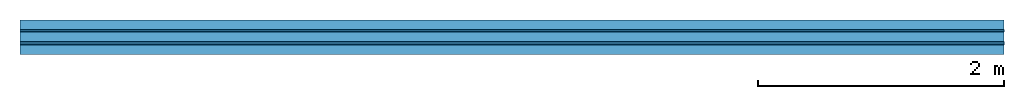
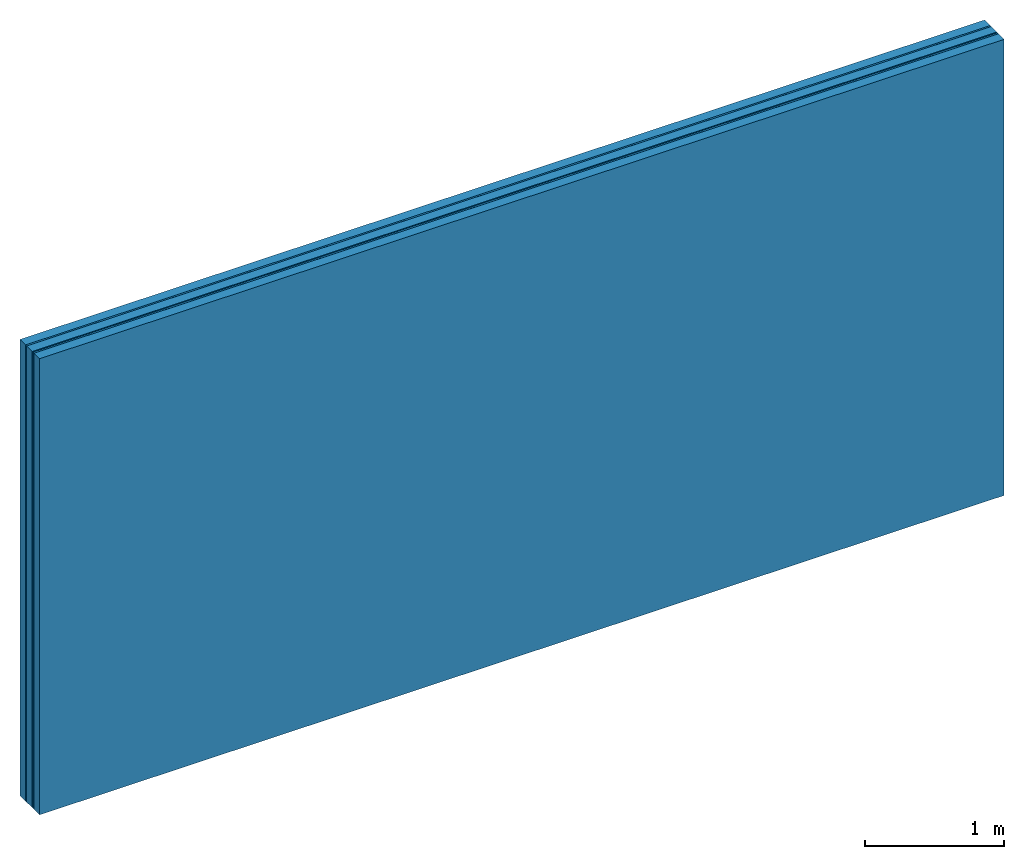
# One storey: 4 plates, 2 members, 1 element without a shape of its own.
"""IFC4 building model written with IfcOpenShell, lengths in metres."""

import ifcopenshell
import ifcopenshell.guid

model = None  # the IFC model being written
_history = None  # IfcOwnerHistory: only IFC2X3 demands one
_inside = {}  # id of a spatial element -> (the spatial element, [elements in it])
_under = {}  # id of a project, library or spatial element -> (it, [spatial elements below it])
_declared = {}  # id of a project -> (the project, [libraries it declares])
_typed = {}  # id of a type object -> (the type object, [elements of that type])
_made_of = {}  # id of a material, layer set ... -> (it, [elements and type objects made of it])


def new_model(schema):
    """Start an empty IFC model of exactly this schema.

    Asked for "IFC4X3", IfcOpenShell would pick the latest addendum, in which some entities
    have other attributes; the version numbers below select the first issue.
    IFC2X3 requires an IfcOwnerHistory on every rooted entity: one is made here for all.
    """
    global model, _history
    if schema == "IFC4X3":
        model = ifcopenshell.file(schema_version=(4, 3, 0, 0))
    else:
        model = ifcopenshell.file(schema=schema)
    _inside.clear()
    _under.clear()
    _declared.clear()
    _typed.clear()
    _made_of.clear()
    _history = None
    if model.schema == "IFC2X3":
        org = make("IfcOrganization", Name="unknown")
        user = make(
            "IfcPersonAndOrganization",
            ThePerson=make("IfcPerson", FamilyName="unknown"),
            TheOrganization=org,
        )
        app = make(
            "IfcApplication",
            ApplicationDeveloper=org,
            Version="unknown",
            ApplicationFullName="unknown",
            ApplicationIdentifier="unknown",
        )
        _history = make(
            "IfcOwnerHistory",
            OwningUser=user,
            OwningApplication=app,
            ChangeAction="ADDED",
            CreationDate=0,
        )
    return model


def make(cls, **values):
    """One entity of the class cls with the attributes given. An attribute that is None is left unset."""
    return model.create_entity(
        cls, **{name: value for name, value in values.items() if value is not None}
    )


def rooted(cls, **values):
    """An entity with a GlobalId (a new one), such as an element, a storey or a relation."""
    return make(cls, GlobalId=ifcopenshell.guid.new(), OwnerHistory=_history, **values)


def si_unit(unit_type, name, prefix=None):
    """IfcSIUnit, for example si_unit("LENGTHUNIT", "METRE", prefix="MILLI")."""
    return make("IfcSIUnit", UnitType=unit_type, Prefix=prefix, Name=name)


def derived_unit(unit_type, elements):
    """IfcDerivedUnit: a product of units, each with its exponent."""
    return make(
        "IfcDerivedUnit",
        Elements=[
            make("IfcDerivedUnitElement", Unit=unit, Exponent=power)
            for unit, power in elements
        ],
        UnitType=unit_type,
    )


def assignment(units):
    """IfcUnitAssignment: the units of a project."""
    return None if units is None else make("IfcUnitAssignment", Units=units)


def point(xyz):
    """IfcCartesianPoint."""
    return None if xyz is None else make("IfcCartesianPoint", Coordinates=xyz)


def direction(xyz):
    """IfcDirection."""
    return None if xyz is None else make("IfcDirection", DirectionRatios=xyz)


def frame(location, z_axis=None, x_axis=None):
    """IfcAxis2Placement3D, a coordinate frame: its origin and axes. An axis left out is left unset."""
    return make(
        "IfcAxis2Placement3D",
        Location=point(location),
        Axis=direction(z_axis),
        RefDirection=direction(x_axis),
    )


def frame_2d(location, x_axis=None):
    """IfcAxis2Placement2D, a coordinate frame in the plane: its origin and x axis."""
    return make(
        "IfcAxis2Placement2D", Location=point(location), RefDirection=direction(x_axis)
    )


def origin():
    """The frame at (0, 0, 0) with its axes left unset."""
    return frame((0.0, 0.0, 0.0))


def place(relative_to, where):
    """IfcLocalPlacement: puts the frame where relative to a parent placement (None: the world)."""
    return make(
        "IfcLocalPlacement", PlacementRelTo=relative_to, RelativePlacement=where
    )


def context(
    kind, dimensions, precision=None, world=None, true_north=None, identifier=None
):
    """IfcGeometricRepresentationContext, for example the 3D "Model" context."""
    return make(
        "IfcGeometricRepresentationContext",
        ContextIdentifier=identifier,
        ContextType=kind,
        CoordinateSpaceDimension=dimensions,
        Precision=precision,
        WorldCoordinateSystem=world,
        TrueNorth=true_north,
    )


def project(units=None, contexts=None):
    """IfcProject with its units and contexts."""
    return rooted(
        "IfcProject",
        Name="project",
        RepresentationContexts=contexts,
        UnitsInContext=assignment(units),
    )


def spatial(cls, under=None, at=None, **own):
    """A site, building, storey or space (cls), placed at a placement, below another one or the project."""
    s = rooted(cls, ObjectPlacement=at, **own)
    if under is not None:
        _under.setdefault(under.id(), (under, []))[1].append(s)
    return s


def profile(cls, at=None, kind="AREA", **sizes):
    """A parametric profile (cls). Its sizes go by their IFC names, for example OverallWidth=200.0."""
    return make(cls, ProfileType=kind, Position=at, **sizes)


def rectangle(**sizes):
    """IfcRectangleProfileDef."""
    return profile("IfcRectangleProfileDef", **sizes)


def extrude(swept, where, along, depth):
    """IfcExtrudedAreaSolid: the profile swept, set in the frame where, extruded along a direction by depth."""
    return make(
        "IfcExtrudedAreaSolid",
        SweptArea=swept,
        Position=where,
        ExtrudedDirection=direction(along),
        Depth=depth,
    )


def shape(context_of_items, identifier, shape_type, items):
    """IfcShapeRepresentation: the items that make up one representation, for example the "Body"."""
    return make(
        "IfcShapeRepresentation",
        ContextOfItems=context_of_items,
        RepresentationIdentifier=identifier,
        RepresentationType=shape_type,
        Items=items,
    )


def material(Name=None, Category=None):
    """IfcMaterial."""
    return make("IfcMaterial", Name=Name, Category=Category)


def layer(
    of_material, thickness, ventilated=None, Name=None, Category=None, Priority=None
):
    """IfcMaterialLayer: one layer of a wall or slab, of a material (None: an air gap)."""
    return make(
        "IfcMaterialLayer",
        Material=of_material,
        LayerThickness=thickness,
        IsVentilated=ventilated,
        Name=Name,
        Category=Category,
        Priority=Priority,
    )


def layer_set(layers, Name=None):
    """IfcMaterialLayerSet."""
    return make("IfcMaterialLayerSet", MaterialLayers=layers, LayerSetName=Name)


def made_of(thing, what):
    """Note that an element or type object is made of a material, layer set ...; save() writes the relation."""
    if what is not None:
        _made_of.setdefault(what.id(), (what, []))[1].append(thing)
    return thing


def type_object(cls, material=None, **own):
    """A type object (cls), such as IfcWallType, which elements share."""
    return made_of(rooted(cls, **own), material)


def element(
    cls,
    number,
    at=None,
    inside=None,
    cuts=None,
    type_object=None,
    material=None,
    context=None,
    identifier="Body",
    shape_type=None,
    held_by="IfcProductDefinitionShape",
    body=None,
    shapes=None,
    **own,
):
    """One element of the class cls, such as IfcWall. Its Tag is "e" and its number.

    at: its placement. inside: the storey or other place that contains it. cuts: it is an
    opening in that element (IfcRelVoidsElement). A single representation is given by context,
    identifier, shape_type and body (its items); several are given by shapes. held_by: the class
    of the entity that holds the representations. save() writes the other relations.
    """
    e = rooted(cls, Tag="e%d" % number, ObjectPlacement=at, **own)
    if body is not None:
        shapes = [shape(context, identifier, shape_type, body)]
    if shapes is not None:
        e.Representation = make(held_by, Representations=shapes)
    if inside is not None:
        _inside.setdefault(inside.id(), (inside, []))[1].append(e)
    if cuts is not None:
        rooted(
            "IfcRelVoidsElement", RelatingBuildingElement=cuts, RelatedOpeningElement=e
        )
    if type_object is not None:
        _typed.setdefault(type_object.id(), (type_object, []))[1].append(e)
    return made_of(e, material)


def aggregate(whole, parts):
    """IfcRelAggregates: a whole, such as a stair, and the parts it consists of."""
    return rooted("IfcRelAggregates", RelatingObject=whole, RelatedObjects=parts)


def save(model, path):
    """Write the relations noted so far, then the file.

    IfcRelAggregates (storeys below a building ...), IfcRelContainedInSpatialStructure (elements
    in a storey), IfcRelDefinesByType, IfcRelAssociatesMaterial and IfcRelDeclares: one each for
    every whole, place, type object, material and project.
    """
    for whole, parts in _under.values():
        aggregate(whole, parts)
    for where, things in _inside.values():
        rooted(
            "IfcRelContainedInSpatialStructure",
            RelatedElements=things,
            RelatingStructure=where,
        )
    for kind, things in _typed.values():
        rooted("IfcRelDefinesByType", RelatedObjects=things, RelatingType=kind)
    for what, things in _made_of.values():
        rooted("IfcRelAssociatesMaterial", RelatedObjects=things, RelatingMaterial=what)
    for by, libraries in _declared.values():
        rooted("IfcRelDeclares", RelatingContext=by, RelatedDefinitions=libraries)
    model.write(path)


model = new_model("IFC4")

# Units and contexts
plan_context = context("Plan", 3, precision=1e-05, world=origin(), true_north=direction((0.0, 1.0)))
model_context = context("Model", 3, precision=1e-05, world=origin(), true_north=direction((0.0, 1.0)))
ifc_project = project(units=[si_unit("LENGTHUNIT", "METRE"), derived_unit("SOUNDPRESSUREUNIT", [(si_unit("PRESSUREUNIT", "PASCAL", prefix="MICRO"), 0)]), si_unit("ENERGYUNIT", "JOULE", prefix="MEGA"), si_unit("MASSUNIT", "GRAM", prefix="KILO"), derived_unit("THERMALTRANSMITTANCEUNIT", [(si_unit("POWERUNIT", "WATT"), 1), (si_unit("AREAUNIT", "SQUARE_METRE"), -1), (si_unit("THERMODYNAMICTEMPERATUREUNIT", "KELVIN"), -1)]), derived_unit("AREADENSITYUNIT", [(si_unit("MASSUNIT", "GRAM", prefix="KILO"), 1), (si_unit("AREAUNIT", "SQUARE_METRE"), -1)]), derived_unit("USERDEFINED", [(si_unit("ENERGYUNIT", "JOULE", prefix="MEGA"), 1), (si_unit("AREAUNIT", "SQUARE_METRE"), -1)])], contexts=[plan_context, model_context])

# Site, building, storey
site = spatial("IfcSite", under=ifc_project)
building_placement = place(None, origin())
building = spatial("IfcBuilding", under=site, at=building_placement)
storey_placement = place(building_placement, origin())
storey = spatial("IfcBuildingStorey", under=building, at=storey_placement)

# Wall, members, plates
ifc_material_1 = material(Name="of the art")
ifc_layer_1 = layer(ifc_material_1, 0.0, Name="Bond")
ifc_layer_2 = layer(None, 0.08, Name="Support")
ifc_layer_3 = layer(ifc_material_1, 0.0, Name="Bond")
ifc_material_2 = material(Category="03.007")
ifc_layer_4 = layer(ifc_material_2, 0.015, Name="outside 1st layer")
ifc_material_3 = material(Category="10.008")
ifc_layer_5 = layer(ifc_material_3, 0.08, Name="Intermediate insulation")
ifc_material_4 = material(Name="Air")
ifc_layer_6 = layer(ifc_material_4, 0.01, Name="Air gap")
ifc_layer_7 = layer(ifc_material_2, 0.015, Name="outside 1st layer")
ifc_layer_8 = layer(ifc_material_1, 0.0, Name="Bond")
ifc_layer_9 = layer(None, 0.08, Name="Support")
ifc_layer_10 = layer(ifc_material_1, 0.0, Name="Bond")
ifc_layer_set = layer_set([ifc_layer_1, ifc_layer_2, ifc_layer_3, ifc_layer_4, ifc_layer_5, ifc_layer_6, ifc_layer_7, ifc_layer_8, ifc_layer_9, ifc_layer_10])
wall_type = type_object("IfcWallType", Name="B0256", PredefinedType="NOTDEFINED", material=ifc_layer_set)
wall_placement = place(None, frame((0.0, 0.0, 0.0), z_axis=(0.0, -1.0, 0.0), x_axis=(1.0, 0.0, 0.0)))
wall = element("IfcWall", 1, at=wall_placement, inside=storey, type_object=wall_type, material=ifc_layer_set, Name="Wall #1")
ifc_material_5 = material(Name="Solid timber panel")
member_1_placement = place(wall_placement, origin())
member_1 = element("IfcMember", 2, at=member_1_placement, material=ifc_material_5, Name="Support", context=plan_context, shape_type="SweptSolid", body=[
    extrude(rectangle(XDim=1.0, YDim=0.08, at=frame_2d((0.5, 0.04), x_axis=(1.0, 0.0))), frame((0.0, 4.0, 0.0), z_axis=(0.0, -1.0, 0.0), x_axis=(1.0, 0.0, 0.0)), (0.0, 0.0, 1.0), 4.0),
    extrude(rectangle(XDim=1.0, YDim=0.08, at=frame_2d((0.5, 0.04), x_axis=(1.0, 0.0))), frame((1.0, 4.0, 0.0), z_axis=(0.0, -1.0, 0.0), x_axis=(1.0, 0.0, 0.0)), (0.0, 0.0, 1.0), 4.0),
    extrude(rectangle(XDim=1.0, YDim=0.08, at=frame_2d((0.5, 0.04), x_axis=(1.0, 0.0))), frame((2.0, 4.0, 0.0), z_axis=(0.0, -1.0, 0.0), x_axis=(1.0, 0.0, 0.0)), (0.0, 0.0, 1.0), 4.0),
    extrude(rectangle(XDim=1.0, YDim=0.08, at=frame_2d((0.5, 0.04), x_axis=(1.0, 0.0))), frame((3.0, 4.0, 0.0), z_axis=(0.0, -1.0, 0.0), x_axis=(1.0, 0.0, 0.0)), (0.0, 0.0, 1.0), 4.0),
    extrude(rectangle(XDim=1.0, YDim=0.08, at=frame_2d((0.5, 0.04), x_axis=(1.0, 0.0))), frame((4.0, 4.0, 0.0), z_axis=(0.0, -1.0, 0.0), x_axis=(1.0, 0.0, 0.0)), (0.0, 0.0, 1.0), 4.0),
    extrude(rectangle(XDim=1.0, YDim=0.08, at=frame_2d((0.5, 0.04), x_axis=(1.0, 0.0))), frame((5.0, 4.0, 0.0), z_axis=(0.0, -1.0, 0.0), x_axis=(1.0, 0.0, 0.0)), (0.0, 0.0, 1.0), 4.0),
    extrude(rectangle(XDim=1.0, YDim=0.08, at=frame_2d((0.5, 0.04), x_axis=(1.0, 0.0))), frame((6.0, 4.0, 0.0), z_axis=(0.0, -1.0, 0.0), x_axis=(1.0, 0.0, 0.0)), (0.0, 0.0, 1.0), 4.0),
    extrude(rectangle(XDim=1.0, YDim=0.08, at=frame_2d((0.5, 0.04), x_axis=(1.0, 0.0))), frame((7.0, 4.0, 0.0), z_axis=(0.0, -1.0, 0.0), x_axis=(1.0, 0.0, 0.0)), (0.0, 0.0, 1.0), 4.0),
])
member_2_placement = place(wall_placement, origin())
member_2 = element("IfcMember", 3, at=member_2_placement, material=ifc_material_5, Name="Support", context=plan_context, shape_type="SweptSolid", body=[
    extrude(rectangle(XDim=1.0, YDim=0.08, at=frame_2d((0.5, 0.04), x_axis=(1.0, 0.0))), frame((0.0, 4.0, 0.2), z_axis=(0.0, -1.0, 0.0), x_axis=(1.0, 0.0, 0.0)), (0.0, 0.0, 1.0), 4.0),
    extrude(rectangle(XDim=1.0, YDim=0.08, at=frame_2d((0.5, 0.04), x_axis=(1.0, 0.0))), frame((1.0, 4.0, 0.2), z_axis=(0.0, -1.0, 0.0), x_axis=(1.0, 0.0, 0.0)), (0.0, 0.0, 1.0), 4.0),
    extrude(rectangle(XDim=1.0, YDim=0.08, at=frame_2d((0.5, 0.04), x_axis=(1.0, 0.0))), frame((2.0, 4.0, 0.2), z_axis=(0.0, -1.0, 0.0), x_axis=(1.0, 0.0, 0.0)), (0.0, 0.0, 1.0), 4.0),
    extrude(rectangle(XDim=1.0, YDim=0.08, at=frame_2d((0.5, 0.04), x_axis=(1.0, 0.0))), frame((3.0, 4.0, 0.2), z_axis=(0.0, -1.0, 0.0), x_axis=(1.0, 0.0, 0.0)), (0.0, 0.0, 1.0), 4.0),
    extrude(rectangle(XDim=1.0, YDim=0.08, at=frame_2d((0.5, 0.04), x_axis=(1.0, 0.0))), frame((4.0, 4.0, 0.2), z_axis=(0.0, -1.0, 0.0), x_axis=(1.0, 0.0, 0.0)), (0.0, 0.0, 1.0), 4.0),
    extrude(rectangle(XDim=1.0, YDim=0.08, at=frame_2d((0.5, 0.04), x_axis=(1.0, 0.0))), frame((5.0, 4.0, 0.2), z_axis=(0.0, -1.0, 0.0), x_axis=(1.0, 0.0, 0.0)), (0.0, 0.0, 1.0), 4.0),
    extrude(rectangle(XDim=1.0, YDim=0.08, at=frame_2d((0.5, 0.04), x_axis=(1.0, 0.0))), frame((6.0, 4.0, 0.2), z_axis=(0.0, -1.0, 0.0), x_axis=(1.0, 0.0, 0.0)), (0.0, 0.0, 1.0), 4.0),
    extrude(rectangle(XDim=1.0, YDim=0.08, at=frame_2d((0.5, 0.04), x_axis=(1.0, 0.0))), frame((7.0, 4.0, 0.2), z_axis=(0.0, -1.0, 0.0), x_axis=(1.0, 0.0, 0.0)), (0.0, 0.0, 1.0), 4.0),
])
plate_1_placement = place(wall_placement, origin())
plate_1 = element("IfcPlate", 4, at=plate_1_placement, material=ifc_material_2, Name="outside 1st layer", context=plan_context, shape_type="SweptSolid", body=[
    extrude(rectangle(XDim=8.0, YDim=4.0, at=frame_2d((4.0, 2.0), x_axis=(1.0, 0.0))), frame((0.0, 0.0, 0.08), z_axis=(0.0, 0.0, 1.0), x_axis=(1.0, 0.0, 0.0)), (0.0, 0.0, 1.0), 0.015),
])
plate_2_placement = place(wall_placement, origin())
plate_2 = element("IfcPlate", 5, at=plate_2_placement, material=ifc_material_3, Name="Intermediate insulation", context=plan_context, shape_type="SweptSolid", body=[
    extrude(rectangle(XDim=8.0, YDim=4.0, at=frame_2d((4.0, 2.0), x_axis=(1.0, 0.0))), frame((0.0, 0.0, 0.095), z_axis=(0.0, 0.0, 1.0), x_axis=(1.0, 0.0, 0.0)), (0.0, 0.0, 1.0), 0.08),
])
plate_3_placement = place(wall_placement, origin())
plate_3 = element("IfcPlate", 6, at=plate_3_placement, material=ifc_material_4, Name="Air gap", context=plan_context, shape_type="SweptSolid", body=[
    extrude(rectangle(XDim=8.0, YDim=4.0, at=frame_2d((4.0, 2.0), x_axis=(1.0, 0.0))), frame((0.0, 0.0, 0.175), z_axis=(0.0, 0.0, 1.0), x_axis=(1.0, 0.0, 0.0)), (0.0, 0.0, 1.0), 0.01),
])
plate_4_placement = place(wall_placement, origin())
plate_4 = element("IfcPlate", 7, at=plate_4_placement, material=ifc_material_2, Name="outside 1st layer", context=plan_context, shape_type="SweptSolid", body=[
    extrude(rectangle(XDim=8.0, YDim=4.0, at=frame_2d((4.0, 2.0), x_axis=(1.0, 0.0))), frame((0.0, 0.0, 0.185), z_axis=(0.0, 0.0, 1.0), x_axis=(1.0, 0.0, 0.0)), (0.0, 0.0, 1.0), 0.015),
])
aggregate(wall, [member_1, plate_1, plate_2, plate_3, plate_4, member_2])

save(model, "model.ifc")
